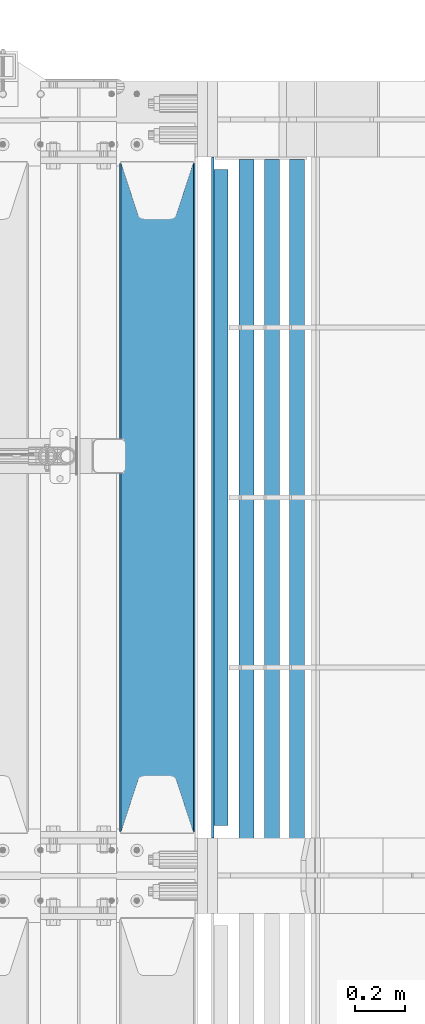
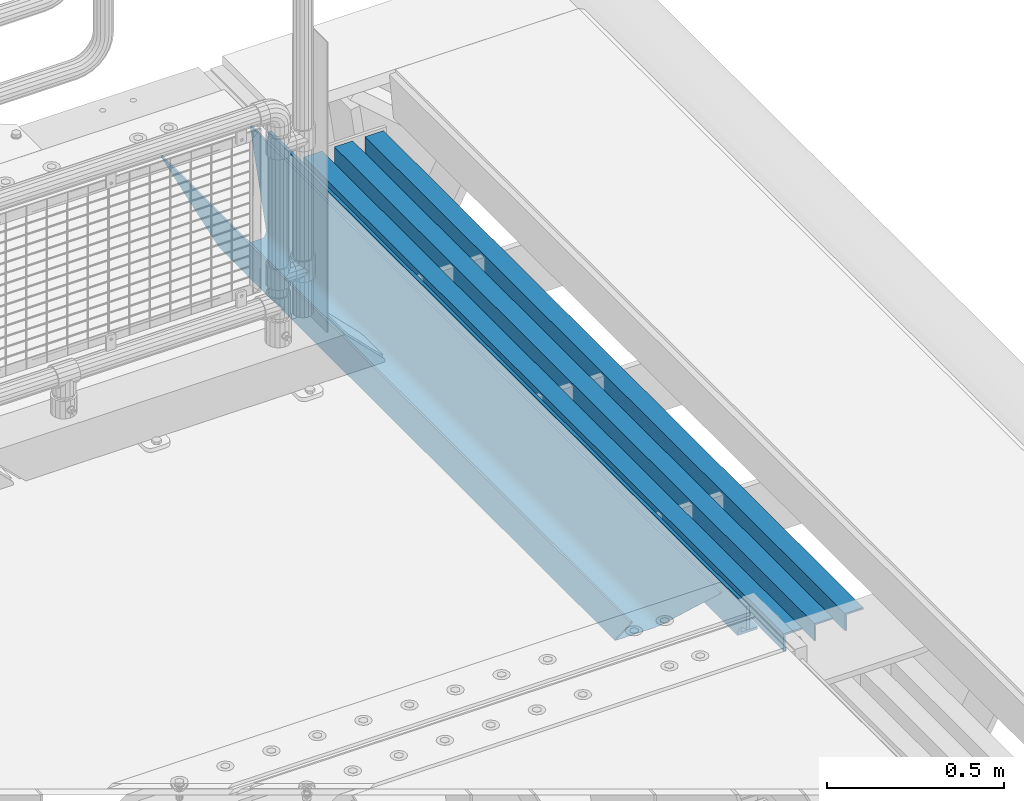
# One storey, part 149 of 270: 5 beams.
"""IFC2X3 building model written with IfcOpenShell, lengths in millimetres."""

from ifc_helpers import new_model, si_unit, frame, origin_with_axes, place, context, subcontext, project, spatial, faceted_brep, material, type_object, element, save


model = new_model("IFC2X3")

# Units and contexts
model_context = context("Model", 3, precision=1e-05, world=origin_with_axes())
body_context = subcontext(model_context, "Body", "Model", "MODEL_VIEW")
ifc_project = project(units=[si_unit("LENGTHUNIT", "METRE", prefix="MILLI"), si_unit("AREAUNIT", "SQUARE_METRE"), si_unit("VOLUMEUNIT", "CUBIC_METRE"), si_unit("MASSUNIT", "GRAM", prefix="KILO"), si_unit("TIMEUNIT", "SECOND"), si_unit("PLANEANGLEUNIT", "RADIAN"), si_unit("SOLIDANGLEUNIT", "STERADIAN"), si_unit("THERMODYNAMICTEMPERATUREUNIT", "DEGREE_CELSIUS"), si_unit("LUMINOUSINTENSITYUNIT", "LUMEN")], contexts=[model_context])

# Site, building, storey
site_placement = place(None, origin_with_axes())
site = spatial("IfcSite", under=ifc_project, at=site_placement, CompositionType="ELEMENT")
building_placement = place(site_placement, origin_with_axes())
building = spatial("IfcBuilding", under=site, at=building_placement, Name="Standard", CompositionType="ELEMENT")
storey_placement = place(building_placement, origin_with_axes())
storey = spatial("IfcBuildingStorey", under=building, at=storey_placement, Name="Undefined", CompositionType="ELEMENT", Elevation=0.0)

# Beams
ifc_material_1 = material(Name="STEEL/S355N")
beam_type_1 = type_object("IfcBeamType", PredefinedType="NOTDEFINED")
beam_1_placement = place(storey_placement, frame((20230.0, -17825.0, -115.0), z_axis=(0.0, 0.0, 1.0), x_axis=(0.0, 1.0, 0.0)))
element("IfcBeam", 1, at=beam_1_placement, inside=storey, type_object=beam_type_1, material=ifc_material_1, context=body_context, shape_type="Brep", body=[
    faceted_brep([(0.0, 150.0, 115.0), (0.0, 143.689999999999, 115.0), (2650.00000000297, 143.689999999999, 115.0), (2650.00000000297, 150.0, 115.0), (2650.00000000297, 142.059565218398, 110.000000003096), (2650.00000000297, 148.3695652184, 110.000000003096), (2441.90079219209, -80.1103600731112, -98.0992078077845), (2437.7588105432, -77.5672621345584, -102.241189456673), (2434.06523489747, -74.4080125315522, -105.934765102404), (2430.9108609509, -70.710272125576, -109.089139048974), (2428.37322971128, -66.5649389910068, -111.626770288588), (2426.51472138055, -62.0739139532889, -113.485278619323), (2425.38102192092, -57.3475956567672, -114.618978078955), (2424.99999999987, -52.5021667386536, -115.0), (2424.99999999987, 52.5021667386536, -115.0), (2425.38102192092, 57.3475956567672, -114.618978078955), (2426.51472138055, 62.0739139532889, -113.485278619323), (2428.37322971128, 66.5649389910068, -111.626770288588), (2430.9108609509, 70.710272125576, -109.089139048974), (2434.06523489747, 74.4080125315522, -105.934765102404), (2437.7588105432, 77.5672621345584, -102.241189456673), (2441.90079219209, 80.1103600731112, -98.0992078077846), (2446.38936140511, 81.9747917625791, -93.6106385947584), (2448.2494850041, 76.2713538057251, -91.7505149957729), (2444.62967112263, 74.76777986261, -95.3703288772456), (2441.28936334126, 72.7168944282894, -98.710636658607), (2438.31067330439, 70.1691124903846, -101.689326695487), (2435.76682334747, 67.1870637758839, -104.233176652398), (2433.72034654133, 63.8440531834895, -106.279653458539), (2432.22154950042, 60.222258798236, -107.778450499454), (2431.30727574265, 56.4107117849089, -108.692724257221), (2430.99999999987, 52.5031078186876, -109.0), (2430.99999999987, -52.5031078186876, -109.0), (2431.30727574265, -56.4107117849089, -108.692724257221), (2432.22154950042, -60.222258798236, -107.778450499454), (2433.72034654133, -63.8440531834895, -106.279653458539), (2435.76682334747, -67.1870637758839, -104.233176652398), (2438.31067330438, -70.1691124903846, -101.689326695487), (2441.28936334126, -72.7168944282894, -98.7106366586071), (2444.62967112263, -74.76777986261, -95.3703288772457), (2448.2494850041, -76.2713538057251, -91.7505149957729), (2650.00000000297, -142.059565218398, 110.000000003096), (2650.00000000297, -148.3695652184, 110.000000003096), (2446.38936140511, -81.9747917625791, -93.6106385947584), (2650.00000000297, -143.689999999999, 115.0), (2650.00000000297, -150.0, 115.0), (0.0, -143.689999999999, 115.0), (0.0, -150.0, 115.0), (0.0, -148.369565218261, 110.000000002672), (203.610638597431, -81.9747917625791, -93.6106385947584), (208.099207810457, -80.1103600731112, -98.0992078077845), (212.241189459342, -77.5672621345584, -102.241189456673), (215.934765105078, -74.4080125315522, -105.934765102404), (219.089139051644, -70.710272125576, -109.089139048974), (221.626770291259, -66.5649389910068, -111.626770288588), (223.485278621993, -62.0739139532889, -113.485278619323), (224.618978081628, -57.3475956567672, -114.618978078955), (225.00000000267, -52.5021667386536, -115.0), (225.00000000267, 52.5021667386536, -115.0), (224.618978081628, 57.3475956567672, -114.618978078955), (223.485278621993, 62.0739139532889, -113.485278619323), (221.626770291259, 66.5649389910068, -111.626770288588), (219.089139051644, 70.710272125576, -109.089139048974), (215.934765105078, 74.4080125315522, -105.934765102404), (212.241189459342, 77.5672621345584, -102.241189456673), (208.099207810457, 80.1103600731112, -98.0992078077846), (203.610638597431, 81.9747917625791, -93.6106385947584), (0.0, 148.369565218261, 110.000000002672), (0.0, 142.05956521826, 110.000000002672), (201.750514998446, 76.2713538057251, -91.7505149957729), (205.370328879915, 74.76777986261, -95.3703288772456), (208.710636661279, 72.7168944282894, -98.710636658607), (211.689326698157, 70.1691124903846, -101.689326695487), (214.233176655071, 67.1870637758839, -104.233176652398), (216.27965346121, 63.8440531834895, -106.279653458539), (217.778450502126, 60.222258798236, -107.778450499454), (218.692724259894, 56.4107117849089, -108.692724257221), (219.00000000267, 52.5031078186876, -109.0), (219.00000000267, -52.5031078186876, -109.0), (218.692724259894, -56.4107117849089, -108.692724257221), (217.778450502123, -60.222258798236, -107.778450499454), (216.27965346121, -63.8440531834895, -106.279653458539), (214.233176655071, -67.1870637758839, -104.233176652398), (211.689326698157, -70.1691124903846, -101.689326695487), (208.710636661279, -72.7168944282894, -98.7106366586071), (205.370328879915, -74.76777986261, -95.3703288772457), (201.750514998446, -76.2713538057251, -91.7505149957729), (0.0, -142.05956521826, 110.000000002672)], [[[0, 1, 2, 3]], [[3, 2, 4, 5]], [[6, 7, 8, 9, 10, 11, 12, 13, 14, 15, 16, 17, 18, 19, 20, 21, 22, 5, 4, 23, 24, 25, 26, 27, 28, 29, 30, 31, 32, 33, 34, 35, 36, 37, 38, 39, 40, 41, 42, 43]], [[44, 45, 42, 41]], [[46, 47, 45, 44]], [[43, 42, 45, 47, 48, 49]], [[6, 43, 49, 50]], [[7, 6, 50, 51]], [[8, 7, 51, 52]], [[9, 8, 52, 53]], [[10, 9, 53, 54]], [[11, 10, 54, 55]], [[12, 11, 55, 56]], [[13, 12, 56, 57]], [[14, 13, 57, 58]], [[15, 14, 58, 59]], [[16, 15, 59, 60]], [[17, 16, 60, 61]], [[18, 17, 61, 62]], [[19, 18, 62, 63]], [[20, 19, 63, 64]], [[21, 20, 64, 65]], [[22, 21, 65, 66]], [[0, 3, 5, 22, 66, 67]], [[1, 0, 67, 68]], [[23, 4, 2, 1, 68, 69]], [[24, 23, 69, 70]], [[25, 24, 70, 71]], [[26, 25, 71, 72]], [[27, 26, 72, 73]], [[28, 27, 73, 74]], [[29, 28, 74, 75]], [[30, 29, 75, 76]], [[31, 30, 76, 77]], [[32, 31, 77, 78]], [[33, 32, 78, 79]], [[34, 33, 79, 80]], [[35, 34, 80, 81]], [[36, 35, 81, 82]], [[37, 36, 82, 83]], [[38, 37, 83, 84]], [[39, 38, 84, 85]], [[40, 39, 85, 86]], [[46, 44, 41, 40, 86, 87]], [[47, 46, 87, 48]], [[86, 85, 84, 83, 82, 81, 80, 79, 78, 77, 76, 75, 74, 73, 72, 71, 70, 69, 68, 67, 66, 65, 64, 63, 62, 61, 60, 59, 58, 57, 56, 55, 54, 53, 52, 51, 50, 49, 48, 87]]]),
])
ifc_material_2 = material(Name="STEEL/S355J2")
beam_type_2 = type_object("IfcBeamType", PredefinedType="NOTDEFINED")
beam_2_placement = place(storey_placement, frame((20477.5025260065, -17850.0, -124.999999999993), z_axis=(0.0, 0.0, 1.0), x_axis=(0.0, 1.0, 0.0)))
element("IfcBeam", 2, at=beam_2_placement, inside=storey, type_object=beam_type_2, material=ifc_material_2, context=body_context, shape_type="Brep", body=[
    faceted_brep([(2700.0, 22.5, -15.0), (2684.54915028125, 22.5, -17.4471741852423), (2684.54915028125, 32.5, -17.4471741852423), (2700.0, 32.5, -15.0), (2670.61073738538, 22.5, -24.5491502812526), (2670.61073738538, 32.5, -24.5491502812526), (2659.54915028125, 22.5, -35.6107373853764), (2659.54915028125, 32.5, -35.6107373853764), (2652.44717418524, 22.5, -49.5491502812526), (2652.44717418524, 32.5, -49.5491502812526), (2651.58384440325, -32.5, -55.0), (2650.0, -32.5, -65.0), (2650.0, 32.5, -65.0), (2651.58384440325, 22.5, -55.0), (0.0, 32.5, 65.0), (0.0, 22.5, 65.0), (2700.0, 22.5, 65.0), (2700.0, 32.5, 65.0), (0.0, 32.5, -15.0), (0.0, 22.5, -15.0), (15.4508497187489, 32.5, -17.4471741852423), (15.4508497187489, 22.5, -17.4471741852423), (29.3892626146226, 32.5, -24.5491502812526), (29.3892626146226, 22.5, -24.5491502812526), (40.4508497187489, 32.5, -35.6107373853763), (40.4508497187489, 22.5, -35.6107373853763), (47.5528258147569, 32.5, -49.5491502812526), (47.5528258147569, 22.5, -49.5491502812526), (50.0, -32.5, -65.0), (48.4161555967512, -32.5, -55.0), (48.4161555967512, 22.5, -55.0), (50.0, 32.5, -65.0)], [[[0, 1, 2, 3]], [[4, 5, 2, 1]], [[6, 7, 5, 4]], [[8, 9, 7, 6]], [[10, 11, 12, 9, 8, 13]], [[14, 15, 16, 17]], [[15, 14, 18, 19]], [[19, 18, 20, 21]], [[21, 20, 22, 23]], [[23, 22, 24, 25]], [[25, 24, 26, 27]], [[28, 29, 30, 27, 26, 31]], [[30, 29, 10, 13]], [[16, 15, 19, 21, 23, 25, 27, 30, 13, 8, 6, 4, 1, 0]], [[17, 16, 0, 3]], [[5, 7, 9, 12, 31, 26, 24, 22, 20, 18, 14, 17, 3, 2]], [[28, 31, 12, 11]], [[29, 28, 11, 10]]]),
])
beam_type_3 = type_object("IfcBeamType", PredefinedType="NOTDEFINED")
for number, where, z_axis, x_axis in (
    (3, (20784.998829901, -15160.0000995858, -209.999999999564), (0.0, 0.0, -1.0), (0.0, -1.0, 0.0)),
    (4, (20684.998829901, -15160.0000995857, -209.999999999564), (0.0, 0.0, -1.0), (0.0, -1.0, 0.0)),
    (5, (20584.9988299003, -15159.9999976612, -209.999999999622), (0.0, 0.0, -1.0), (0.0, -1.0, 0.0)),
):
    element("IfcBeam", number, at=place(storey_placement, frame(where, z_axis=z_axis, x_axis=x_axis)), inside=storey, type_object=beam_type_3, material=ifc_material_2, context=body_context, shape_type="Brep", body=[
        faceted_brep([(3.63797880709171e-12, 29.9999999999927, -30.0), (0.0, 29.9999999999927, 30.0000000000001), (2710.00017042501, 29.9999999999964, 30.0), (2710.00017042501, 29.9999999999964, -30.0), (0.0, 23.9999999999927, 30.0), (2710.00017042501, 23.9999999999964, 30.0), (0.0, 23.9999999999927, -24.0), (2710.00017042501, 23.9999999999964, -24.0), (0.0, -30.0000000000073, -24.0), (2710.00017042501, -30.0000000000036, -24.0), (0.0, -30.0000000000073, -30.0), (2710.00017042501, -30.0000000000036, -30.0)], [[[0, 1, 2, 3]], [[1, 4, 5, 2]], [[4, 6, 7, 5]], [[6, 8, 9, 7]], [[8, 10, 11, 9]], [[10, 0, 3, 11]], [[5, 7, 9, 11, 3, 2]], [[10, 8, 6, 4, 1, 0]]]),
    ])

save(model, "model.ifc")
